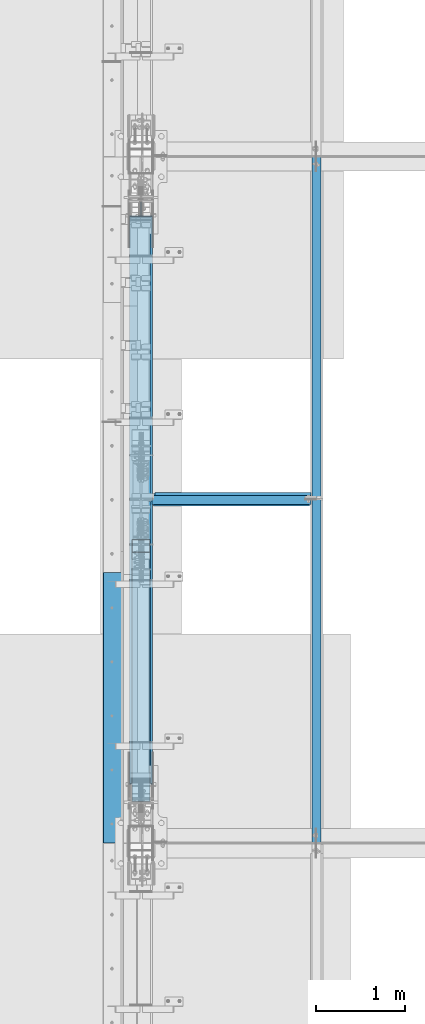
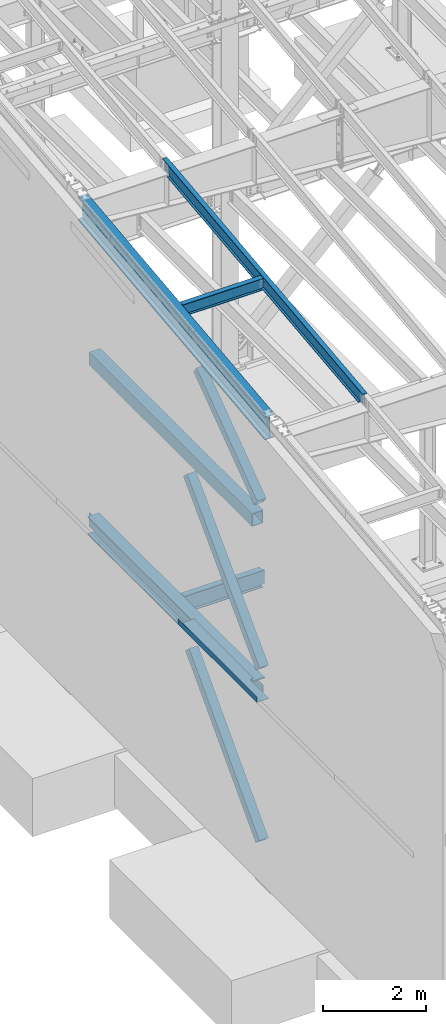
# One storey, part 708 of 1179: 7 beams, 3 members, 9 elements without a shape of their own.
"""IFC2X3 building model written with IfcOpenShell, lengths in millimetres."""

from ifc_helpers import new_model, si_unit, frame, origin_with_axes, place, context, subcontext, project, spatial, faceted_brep, material, type_object, element, aggregate, save


model = new_model("IFC2X3")

# Units and contexts
model_context = context("Model", 3, precision=1e-05, world=origin_with_axes())
body_context = subcontext(model_context, "Body", "Model", "MODEL_VIEW")
ifc_project = project(units=[si_unit("LENGTHUNIT", "METRE", prefix="MILLI"), si_unit("AREAUNIT", "SQUARE_METRE"), si_unit("VOLUMEUNIT", "CUBIC_METRE"), si_unit("MASSUNIT", "GRAM", prefix="KILO"), si_unit("TIMEUNIT", "SECOND"), si_unit("PLANEANGLEUNIT", "RADIAN"), si_unit("SOLIDANGLEUNIT", "STERADIAN"), si_unit("THERMODYNAMICTEMPERATUREUNIT", "DEGREE_CELSIUS"), si_unit("LUMINOUSINTENSITYUNIT", "LUMEN")], contexts=[model_context])

# Site, building, storey
site_placement = place(None, origin_with_axes())
site = spatial("IfcSite", under=ifc_project, at=site_placement, CompositionType="ELEMENT")
building_placement = place(site_placement, origin_with_axes())
building = spatial("IfcBuilding", under=site, at=building_placement, Name="Undefined", CompositionType="ELEMENT")
storey_placement = place(building_placement, origin_with_axes())
storey = spatial("IfcBuildingStorey", under=building, at=storey_placement, Name="Undefined", CompositionType="ELEMENT", Elevation=0.0)

# Assembly, beam
assembly_1_placement = place(storey_placement, origin_with_axes())
assembly_1 = element("IfcElementAssembly", 1, at=assembly_1_placement, inside=storey, Name="BEAM", AssemblyPlace="NOTDEFINED", PredefinedType="RIGID_FRAME")
ifc_material_1 = material(Name="STEEL/A992")
beam_type_1 = type_object("IfcBeamType", Name="W16X31", PredefinedType="NOTDEFINED")
beam_1_placement = place(assembly_1_placement, frame((431.800000000002, 15354.3, 3900.4875), z_axis=(0.0, 0.0, 1.0), x_axis=(1.0, 0.0, 0.0)))
beam_1 = element("IfcBeam", 2, at=beam_1_placement, type_object=beam_type_1, material=ifc_material_1, Name="BEAM", ObjectType="W16X31", context=body_context, shape_type="Brep", body=[
    faceted_brep([(1965.32485351562, -3.17499999999927, 169.862500000001), (1965.32485351562, 3.17499999999927, 169.862500000001), (1911.34985332489, 3.17499999999927, 169.862500000001), (1911.34985332489, -3.17499999999927, 169.862500000001), (1906.48977380684, 3.17499999999927, 170.829229922589), (1906.48977380684, -3.17499999999927, 170.829229922589), (1902.36959733869, 3.17499999999927, 173.582243823067), (1902.36959733869, -3.17499999999927, 173.582243823067), (1901.82485351562, 3.17499999999927, 174.397510567854), (1899.61658343821, 3.17499999999927, 177.70242029122), (1899.61658343821, -3.17499999999927, 177.70242029122), (1898.64985351562, 3.17499999999927, 182.562499809266), (1898.64985351562, -3.17499999999927, 182.562499809266), (142.081250000001, 3.17499999999927, 190.5), (142.081250000001, 69.8499999999985, 190.5), (1898.64985351562, 69.8500000000004, 190.5), (1898.64985351562, 3.17499999999927, 190.5), (142.081250000001, -69.8499999999985, 201.6125), (142.081250000001, -69.8499999999985, 190.5), (1898.64985351562, -69.8500000000004, 190.5), (1898.64985351562, -69.8500000000004, 201.6125), (142.081250000001, 69.8499999999985, 201.6125), (1898.64985351562, 69.8500000000004, 201.6125), (1898.64985351562, -3.17499999999927, 190.5), (142.081250000001, -3.17499999999927, 190.5), (142.08125, 3.17499999999927, 169.862499809265), (142.08125, -3.17499999999927, 169.862499809265), (141.114520077412, 3.17499999999927, 165.00242029122), (141.114520077412, -3.17499999999927, 165.00242029122), (138.361506176934, 3.17499999999927, 160.882243823066), (138.361506176934, -3.17499999999927, 160.882243823066), (134.24132970878, 3.17499999999927, 158.129229922588), (134.24132970878, -3.17499999999927, 158.129229922588), (129.381250190735, 3.17499999999927, 157.1625), (129.381250190735, -3.17499999999927, 157.1625), (18.2562499999996, 3.17499999999927, 157.1625), (18.2562499999996, -3.17499999999927, 157.1625), (18.2562499999996, 3.17499999999927, -157.1625), (18.2562499999996, -3.17499999999927, -157.1625), (129.381250190735, 3.17499999999927, -157.1625), (129.381250190735, -3.17499999999927, -157.1625), (134.24132970878, 3.17499999999927, -158.129229922588), (134.24132970878, -3.17499999999927, -158.129229922588), (138.361506176934, 3.17499999999927, -160.882243823066), (138.361506176934, -3.17499999999927, -160.882243823066), (141.114520077412, 3.17499999999927, -165.00242029122), (141.114520077412, -3.17499999999927, -165.00242029122), (142.08125, 3.17499999999927, -169.862499809266), (142.08125, -3.17499999999927, -169.862499809266), (142.081250000001, 3.17499999999927, -190.5), (142.081250000001, 69.8499999999985, -190.5), (142.081250000001, 69.8499999999985, -201.6125), (142.081250000001, -69.8499999999985, -201.6125), (142.081250000001, -69.8499999999985, -190.5), (142.081250000001, -3.17499999999927, -190.5), (1898.64985351562, 3.17499999999927, -190.5), (1898.64985351562, 69.8500000000004, -190.5), (1898.64985351562, 69.8500000000004, -201.6125), (1898.64985351562, -69.8500000000004, -201.6125), (1898.64985351562, -69.8500000000004, -190.5), (1898.64985351562, -3.17499999999927, -190.5), (1898.64985351562, -3.17499999999927, -182.562499809264), (1899.61658343821, -3.17499999999927, -177.702420291219), (1902.36959733869, -3.17499999999927, -173.582243823065), (1906.48977380684, -3.17499999999927, -170.829229922587), (1911.34985332489, -3.17499999999927, -169.862499999999), (1965.32485351562, -3.17499999999927, -169.862499999999), (1965.32485351562, 3.17499999999927, -169.862499999999), (1906.48977380684, 3.17499999999927, -170.829229922587), (1902.36959733869, 3.17499999999927, -173.582243823065), (1901.82485351562, 3.17499999999927, -174.397510567853), (1899.61658343821, 3.17499999999927, -177.702420291219), (1898.64985351562, 3.17499999999927, -182.562499809264), (1911.34985332489, 3.17499999999927, -169.862499999999)], [[[0, 1, 2, 3]], [[3, 2, 4, 5]], [[5, 4, 6, 7]], [[7, 6, 8, 9, 10]], [[10, 9, 11, 12]], [[13, 14, 15, 16]], [[17, 18, 19, 20]], [[21, 17, 20, 22]], [[14, 21, 22, 15]], [[20, 19, 23, 12, 11, 16, 15, 22]], [[18, 24, 23, 19]], [[17, 21, 14, 13, 25, 26, 24, 18]], [[26, 25, 27, 28]], [[28, 27, 29, 30]], [[30, 29, 31, 32]], [[32, 31, 33, 34]], [[34, 33, 35, 36]], [[36, 35, 37, 38]], [[38, 37, 39, 40]], [[40, 39, 41, 42]], [[42, 41, 43, 44]], [[44, 43, 45, 46]], [[46, 45, 47, 48]], [[48, 47, 49, 50, 51, 52, 53, 54]], [[50, 49, 55, 56]], [[51, 50, 56, 57]], [[52, 51, 57, 58]], [[53, 52, 58, 59]], [[54, 53, 59, 60]], [[0, 3, 5, 7, 10, 12, 23, 24, 26, 28, 30, 32, 34, 36, 38, 40, 42, 44, 46, 48, 54, 60, 61, 62, 63, 64, 65, 66]], [[1, 0, 66, 67]], [[68, 69, 70, 71, 72, 55, 49, 47, 45, 43, 41, 39, 37, 35, 33, 31, 29, 27, 25, 13, 16, 11, 9, 8, 6, 4, 2, 1, 67, 73]], [[66, 65, 73, 67]], [[64, 68, 73, 65]], [[63, 69, 68, 64]], [[62, 71, 70, 69, 63]], [[61, 72, 71, 62]], [[60, 59, 58, 57, 56, 55, 72, 61]]]),
])
aggregate(assembly_1, [beam_1])

# Assembly, member
assembly_2_placement = place(storey_placement, origin_with_axes())
assembly_2 = element("IfcElementAssembly", 3, at=assembly_2_placement, inside=storey, Name="None", AssemblyPlace="NOTDEFINED", PredefinedType="RIGID_FRAME")
member_type = type_object("IfcMemberType", Name="HSS8X8X3/16", PredefinedType="NOTDEFINED")
member_1_placement = place(assembly_2_placement, frame((431.800000000002, 12102.6825319676, 8317.9321736996), z_axis=(1.0, 0.0, 0.0), x_axis=(0.0, 0.806043266248581, 0.591856615182528)))
member_1 = element("IfcMember", 4, at=member_1_placement, type_object=member_type, material=ifc_material_1, Name="None", ObjectType="HSS8X8X3/16", context=body_context, shape_type="Brep", body=[
    faceted_brep([(-3.63797880709171e-12, 96.8374999999978, -96.8375000000015), (-3.63797880709171e-12, -96.8374999999978, -96.8375000000015), (2914.65000001991, -96.8374999971984, -96.8375), (2914.65000001972, 96.8375000027499, -96.8375), (-3.63797880709171e-12, -96.8374999999978, 96.8375000000015), (2914.65000001991, -96.8374999971984, 96.8375), (-3.63797880709171e-12, 96.8374999999978, 96.8375000000015), (2914.65000001972, 96.8375000027499, 96.8375), (-3.63797880709171e-12, 101.599999999999, -101.599999999999), (-3.63797880709171e-12, 101.599999999999, 101.599999999999), (2914.65000001972, 101.600000002747, 101.6), (2914.65000001972, 101.600000002747, -101.6), (0.0, -101.599999999999, 101.599999999999), (2914.65000001991, -101.599999997197, 101.6), (0.0, -101.599999999999, -101.599999999999), (2914.65000001991, -101.599999997197, -101.6)], [[[0, 1, 2, 3]], [[1, 4, 5, 2]], [[4, 6, 7, 5]], [[6, 0, 3, 7]], [[8, 9, 10, 11]], [[9, 12, 13, 10]], [[12, 14, 15, 13]], [[14, 8, 11, 15]], [[13, 15, 11, 10], [5, 7, 3, 2]], [[14, 12, 9, 8], [6, 4, 1, 0]]]),
])
aggregate(assembly_2, [member_1])

assembly_3_placement = place(storey_placement, origin_with_axes())
assembly_3 = element("IfcElementAssembly", 5, at=assembly_3_placement, inside=storey, Name="None", AssemblyPlace="NOTDEFINED", PredefinedType="RIGID_FRAME")
member_2_placement = place(assembly_3_placement, frame((431.799998474123, 12024.6144774088, 4449.73696522314), z_axis=(1.0, 0.0, 0.0), x_axis=(0.0, 0.698466923036852, 0.715642339037758)))
member_2 = element("IfcMember", 6, at=member_2_placement, type_object=member_type, material=ifc_material_1, Name="None", ObjectType="HSS8X8X3/16", context=body_context, shape_type="Brep", body=[
    faceted_brep([(-3.63797880709171e-12, 96.8374999999978, -96.8375000000015), (-3.63797880709171e-12, -96.8374999999978, -96.8375000000015), (4020.12361600279, -96.837499999664, -96.8375), (4020.12361600291, 96.8375000002379, -96.8375), (-3.63797880709171e-12, -96.8374999999978, 96.8375000000015), (4020.12361600279, -96.837499999664, 96.8375), (-3.63797880709171e-12, 96.8374999999978, 96.8375000000015), (4020.12361600291, 96.8375000002379, 96.8375), (-3.63797880709171e-12, 101.599999999999, -101.599999999999), (-3.63797880709171e-12, 101.599999999999, 101.599999999999), (4020.12361600291, 101.600000000234, 101.6), (4020.12361600291, 101.600000000234, -101.6), (0.0, -101.599999999999, 101.599999999999), (4020.12361600278, -101.599999999662, 101.6), (0.0, -101.599999999999, -101.599999999999), (4020.12361600278, -101.599999999662, -101.6)], [[[0, 1, 2, 3]], [[1, 4, 5, 2]], [[4, 6, 7, 5]], [[6, 0, 3, 7]], [[8, 9, 10, 11]], [[9, 12, 13, 10]], [[12, 14, 15, 13]], [[14, 8, 11, 15]], [[13, 15, 11, 10], [5, 7, 3, 2]], [[14, 12, 9, 8], [6, 4, 1, 0]]]),
])
aggregate(assembly_3, [member_2])

assembly_4_placement = place(storey_placement, origin_with_axes())
assembly_4 = element("IfcElementAssembly", 7, at=assembly_4_placement, inside=storey, Name="None", AssemblyPlace="NOTDEFINED", PredefinedType="RIGID_FRAME")
member_3_placement = place(assembly_4_placement, frame((431.800000000002, 12032.5736527125, 369.341890750087), z_axis=(1.0, 0.0, 0.0), x_axis=(0.0, 0.685995858758672, 0.727605443744034)))
member_3 = element("IfcMember", 8, at=member_3_placement, type_object=member_type, material=ifc_material_1, Name="None", ObjectType="HSS8X8X3/16", context=body_context, shape_type="Brep", body=[
    faceted_brep([(-3.63797880709171e-12, 96.8374999999978, -96.8375000000015), (-3.63797880709171e-12, -96.8374999999978, -96.8375000000015), (3968.75000001255, -96.8375000016003, -96.8375), (3968.75000001275, 96.8374999981806, -96.8375), (-3.63797880709171e-12, -96.8374999999978, 96.8375000000015), (3968.75000001255, -96.8375000016003, 96.8375), (-3.63797880709171e-12, 96.8374999999978, 96.8375000000015), (3968.75000001275, 96.8374999981806, 96.8375), (-3.63797880709171e-12, 101.599999999999, -101.599999999999), (-3.63797880709171e-12, 101.599999999999, 101.599999999999), (3968.75000001276, 101.599999998176, 101.6), (3968.75000001276, 101.599999998176, -101.6), (0.0, -101.599999999999, 101.599999999999), (3968.75000001255, -101.600000001596, 101.6), (0.0, -101.599999999999, -101.599999999999), (3968.75000001255, -101.600000001596, -101.6)], [[[0, 1, 2, 3]], [[1, 4, 5, 2]], [[4, 6, 7, 5]], [[6, 0, 3, 7]], [[8, 9, 10, 11]], [[9, 12, 13, 10]], [[12, 14, 15, 13]], [[14, 8, 11, 15]], [[13, 15, 11, 10], [5, 7, 3, 2]], [[14, 12, 9, 8], [6, 4, 1, 0]]]),
])
aggregate(assembly_4, [member_3])

# Assembly, beam
assembly_5_placement = place(storey_placement, origin_with_axes())
assembly_5 = element("IfcElementAssembly", 9, at=assembly_5_placement, inside=storey, Name="BEAM", AssemblyPlace="NOTDEFINED", PredefinedType="RIGID_FRAME")
ifc_material_2 = material(Name="STEEL/A36")
beam_type_2 = type_object("IfcBeamType", PredefinedType="NOTDEFINED")
beam_2_placement = place(assembly_5_placement, frame((352.424987792969, 13007.975, 4105.275), z_axis=(0.0, -1.0, 0.0), x_axis=(-1.0, 0.0, 0.0)))
beam_2 = element("IfcBeam", 10, at=beam_2_placement, type_object=beam_type_2, material=ifc_material_2, Name="BENT_PLATE", context=body_context, shape_type="Brep", body=[
    faceted_brep([(84.1374893188476, -3.17500000000018, 788.651567305722), (84.1374893188476, 3.17500000000018, 788.651567305722), (0.0, 3.17500000000018, 788.651567305722), (0.0, -3.17500000000018, 788.651567305722), (84.1374893188477, -3.17500000000018, 1524.0), (84.1374893188477, 3.17500000000018, 1524.0), (346.074987792969, -3.17500000000109, -1524.0), (0.0, -3.17499999999927, -1524.0), (0.0, 3.17499999999927, -1524.0), (352.424987792969, 3.17499999999927, -1524.0), (352.424987792969, -130.175006103515, -1524.0), (346.074987792969, -130.175006103515, -1524.0), (352.424987792969, 3.17499999999927, 1524.0), (352.424987792969, -130.175006103515, 1524.0), (346.074987792969, -130.175006103515, 1524.0), (346.074987792969, -3.17500000000109, 1524.0)], [[[0, 1, 2, 3]], [[4, 5, 1, 0]], [[6, 7, 8, 9, 10, 11]], [[9, 12, 13, 10]], [[14, 11, 10, 13]], [[15, 6, 11, 14]], [[3, 7, 6, 15, 4, 0]], [[8, 7, 3, 2]], [[12, 9, 8, 2, 1, 5]], [[15, 14, 13, 12, 5, 4]]]),
])

assembly_6_placement = place(storey_placement, origin_with_axes())
assembly_6 = element("IfcElementAssembly", 11, at=assembly_6_placement, inside=storey, Name="BEAM", AssemblyPlace="NOTDEFINED", PredefinedType="RIGID_FRAME")
beam_type_3 = type_object("IfcBeamType", Name="W12X22", PredefinedType="NOTDEFINED")
beam_3_placement = place(assembly_6_placement, frame((431.800000000002, 15371.7779321814, 10827.3055548262), z_axis=(0.0, -0.112284087038017, 0.993676146336441), x_axis=(1.0, 0.0, 0.0)))
beam_3 = element("IfcBeam", 12, at=beam_3_placement, type_object=beam_type_3, material=ifc_material_1, Name="BEAM", ObjectType="W12X22", context=body_context, shape_type="Brep", body=[
    faceted_brep([(1917.7, -3.1750000000502, -144.462499999914), (1917.7, -50.8000000000247, -144.462499999896), (1917.7, -50.8000000000284, -155.574999999892), (1917.7, 50.7999999999156, -155.574999999932), (1917.7, 50.7999999999192, -144.46249999994), (1917.7, 3.17499999869324, -144.462499999918), (1917.7, 3.17499998151106, -142.874999810523), (1917.7, -3.17500000004657, -142.874999810521), (1918.66672992259, 3.17499998191852, -138.014920292486), (1918.66672992259, -3.17500000004657, -138.014920292482), (1921.41974382307, 3.17499998226413, -133.894743824339), (1921.41974382307, -3.17500000004293, -133.894743824334), (1925.53992029122, 3.17499998249332, -131.141729923864), (1925.53992029122, -3.17500000004293, -131.141729923862), (1930.39999980926, 3.17499998257699, -130.175000001278), (1930.39999980926, -3.17500000004293, -130.175000001276), (1965.325, -3.17500000004293, -130.175000001276), (1965.325, 3.17499999995198, -130.175000001278), (121.44375, 3.17500000006476, 144.462499999918), (121.44375, 50.8000000000357, 144.4624999999), (1917.7, 50.8000000000357, 144.4624999999), (1917.7, 3.17500000006476, 144.462499999918), (159.54375, 50.7999999999192, -144.46249999994), (159.54375, 50.7999999999156, -155.574999999932), (159.54375, 3.17499995235266, -155.574999999913), (159.54375, 3.17499995235994, -144.462499999918), (19.8437500000002, 3.17499995235266, -155.574999999913), (19.8437500000002, 3.17499999994834, -144.46249999992), (19.8437500000002, -50.8000000000284, -155.574999999892), (19.8437500000002, -50.8000000000247, -144.462499999896), (19.8437500000002, -3.1750000000502, -144.462499999914), (19.8437500000002, -3.1749999999447, 117.474999998307), (19.8437500000002, 3.17500000005384, 117.474999998303), (108.743750190735, -3.1749999999447, 117.474999998307), (108.743750190735, 3.17500000199652, 117.474999998303), (113.603829708781, -3.1749999999447, 118.441729920891), (113.603829708781, 3.17500000207292, 118.441729920887), (117.724006176934, -3.1749999999447, 121.194743821365), (117.724006176934, 3.17500000229848, 121.194743821363), (120.477020077412, -3.17499999993743, 125.314920289511), (120.477020077412, 3.17500000264045, 125.314920289509), (121.44375, -3.17499999993743, 130.174999807548), (121.44375, 3.17500000304426, 130.174999807547), (121.44375, -50.799999999901, 155.574999999935), (121.44375, 50.8000000000429, 155.574999999893), (121.44375, -3.17499999993379, 144.462499999923), (121.44375, -50.7999999999047, 144.462499999941), (1917.7, -3.17499999993379, 144.462499999923), (1917.7, -50.7999999999047, 144.462499999941), (1917.7, -50.799999999901, 155.574999999935), (1917.7, 50.8000000000429, 155.574999999893), (1917.7, -3.17499999993015, 142.874999807531), (1917.7, 3.17500000523796, 142.874999807529), (1918.66672992259, -3.17499999993379, 138.014920289494), (1918.66672992259, 3.17500000483415, 138.01492028949), (1921.41974382307, -3.17499999993743, 133.894743821347), (1921.41974382307, 3.17500000449218, 133.894743821345), (1925.53992029122, -3.17499999993379, 131.141729920873), (1925.53992029122, 3.17500000425935, 131.141729920872), (1930.39999980926, -3.17499999994106, 130.174999998288), (1930.39999980926, 3.17500000417931, 130.174999998286), (1965.325, -3.17499999994106, 130.174999998288), (1965.325, 3.17500000005748, 130.174999998284)], [[[0, 1, 2, 3, 4, 5, 6, 7]], [[7, 6, 8, 9]], [[9, 8, 10, 11]], [[11, 10, 12, 13]], [[13, 12, 14, 15]], [[16, 15, 14, 17]], [[18, 19, 20, 21]], [[22, 23, 24, 25]], [[25, 24, 26, 27]], [[27, 26, 28, 29, 30, 31, 32]], [[33, 34, 32, 31]], [[35, 36, 34, 33]], [[37, 38, 36, 35]], [[39, 40, 38, 37]], [[41, 42, 40, 39]], [[43, 44, 19, 18, 42, 41, 45, 46]], [[46, 45, 47, 48]], [[43, 46, 48, 49]], [[44, 43, 49, 50]], [[19, 44, 50, 20]], [[49, 48, 47, 51, 52, 21, 20, 50]], [[53, 54, 52, 51]], [[55, 56, 54, 53]], [[57, 58, 56, 55]], [[59, 60, 58, 57]], [[61, 62, 60, 59]], [[62, 61, 16, 17]], [[12, 10, 8, 6, 5, 25, 27, 32, 34, 36, 38, 40, 42, 18, 21, 52, 54, 56, 58, 60, 62, 17, 14]], [[22, 25, 5, 4]], [[23, 22, 4, 3]], [[28, 26, 24, 23, 3, 2]], [[29, 28, 2, 1]], [[30, 29, 1, 0]], [[61, 59, 57, 55, 53, 51, 47, 45, 41, 39, 37, 35, 33, 31, 30, 0, 7, 9, 11, 13, 15, 16]]]),
])
aggregate(assembly_6, [beam_3])

assembly_7_placement = place(storey_placement, origin_with_axes())
assembly_7 = element("IfcElementAssembly", 13, at=assembly_7_placement, inside=storey, Name="BEAM", AssemblyPlace="NOTDEFINED", PredefinedType="RIGID_FRAME")
beam_4_placement = place(assembly_7_placement, frame((2413.0, 11498.2779321842, 10389.6051906331), z_axis=(0.0, -0.112284087038017, 0.993676146336441), x_axis=(0.0, 0.993676146336441, 0.112284087038017)))
beam_4 = element("IfcBeam", 14, at=beam_4_placement, type_object=beam_type_3, material=ifc_material_1, Name="BEAM", ObjectType="W12X22", context=body_context, shape_type="Brep", body=[
    faceted_brep([(7583.46730043383, -3.17499999999927, -144.462500002994), (7583.46730043383, -50.7999999999993, -144.462500002994), (7582.21160266769, -50.7999999999993, -155.575000002988), (7582.21160266769, 50.7999999999993, -155.575000002988), (7583.46730043383, 50.7999999999993, -144.462500002994), (7583.46730043383, 3.17499999999927, -144.462500002994), (7586.83832669432, 3.17499999999927, -114.630059163946), (7586.83832669432, -3.17499999999927, -114.630059163946), (7588.34465274973, 3.17499999999927, -109.909262464753), (7588.34465274973, -3.17499999999927, -109.909262464753), (7591.54288724583, 3.17499999999927, -106.124261042249), (7591.54288724583, -3.17499999999927, -106.124261042249), (7595.94612797272, 3.17499999999927, -103.851287051781), (7595.94612797272, -3.17499999999927, -103.851287051781), (7600.88402144536, 3.17499999999927, -103.436380178771), (7600.88402144536, -3.17499999999927, -103.436380178771), (7758.6208335002, -3.17499999999927, -121.260430776909), (7758.62083354224, 3.17499999999927, -121.26043078166), (6.38101702707718, -50.7999999999993, 155.574999999912), (5.12531926095107, -50.7999999999993, 144.46249999992), (7788.64717240277, -50.7999999999993, 144.462499996762), (7789.9028701689, -50.7999999999993, 155.574999996754), (6.38101702707718, 50.7999999999993, 155.574999999912), (7789.9028701689, 50.7999999999993, 155.574999996754), (5.12531926095107, 50.7999999999993, 144.46249999992), (7788.64717240277, 50.7999999999993, 144.462499996762), (5.12531926095107, 3.17499999999927, 144.46249999992), (7788.64717240277, 3.17499999999927, 144.462499996762), (145.30344487597, -3.17499999999927, -142.022226300664), (145.30344487597, 3.17499999999927, -142.022226300664), (145.027696926005, 3.17499999999927, -144.462499999976), (145.027696926005, 50.7999999999993, -144.462499999976), (143.771999161854, 50.7999999999993, -155.574999999972), (143.771999161854, -50.7999999999993, -155.574999999972), (145.027696926005, -50.7999999999993, -144.462499999976), (145.027696926005, -3.17499999999927, -144.462499999976), (-25.0716067072917, -3.17499999999927, -122.770071196437), (-25.0716067072917, 3.17499999999927, -122.770071196437), (5.12531926095107, -3.17499999999927, 144.46249999992), (7788.64717240277, -3.17499999999927, 144.462499996762)], [[[0, 1, 2, 3, 4, 5, 6, 7]], [[7, 6, 8, 9]], [[9, 8, 10, 11]], [[11, 10, 12, 13]], [[13, 12, 14, 15]], [[16, 15, 14, 17]], [[18, 19, 20, 21]], [[22, 18, 21, 23]], [[24, 22, 23, 25]], [[26, 24, 25, 27]], [[28, 29, 30, 31, 32, 33, 34, 35]], [[36, 37, 29, 28]], [[38, 19, 18, 22, 24, 26, 37, 36]], [[19, 38, 39, 20]], [[27, 25, 23, 21, 20, 39, 16, 17]], [[12, 10, 8, 6, 5, 30, 29, 37, 26, 27, 17, 14]], [[31, 30, 5, 4]], [[32, 31, 4, 3]], [[33, 32, 3, 2]], [[34, 33, 2, 1]], [[35, 34, 1, 0]], [[39, 38, 36, 28, 35, 0, 7, 9, 11, 13, 15, 16]]]),
])
aggregate(assembly_7, [beam_4])

assembly_8_placement = place(storey_placement, origin_with_axes())
assembly_8 = element("IfcElementAssembly", 15, at=assembly_8_placement, inside=storey, Name="BEAM", AssemblyPlace="NOTDEFINED", PredefinedType="RIGID_FRAME")
beam_type_4 = type_object("IfcBeamType", Name="W21X93", PredefinedType="NOTDEFINED")
beam_5_placement = place(assembly_8_placement, frame((431.800000000002, 11511.6467563166, 10271.2956244622), z_axis=(0.0, -0.112284087038017, 0.993676146336441), x_axis=(0.0, 0.993676146336441, 0.112284087038017)))
beam_5 = element("IfcBeam", 16, at=beam_5_placement, type_object=beam_type_4, material=ifc_material_1, Name="BEAM", ObjectType="W21X93", context=body_context, shape_type="Brep", body=[
    faceted_brep([(199.930151815766, -106.362499999999, -274.637499999924), (199.930151815766, 106.362499999999, -274.637499999924), (7473.81664542463, 106.362499999999, -274.637500002875), (7473.81664542463, -106.362499999999, -274.637500002875), (202.620932743182, -106.362499999999, -250.824999999939), (202.620932743182, -7.14374999999927, -250.824999999939), (214.511782852391, -7.14375000000001, -145.595003258248), (259.165541301194, -7.14375000000001, 249.575637438327), (259.306717614098, -7.14374999999927, 250.824999999757), (259.306717614098, -106.362499999999, 250.824999999757), (261.997498541514, -106.362499999999, 274.637499999742), (261.997498541514, 106.362499999999, 274.637499999742), (259.306717614098, 106.362499999999, 250.824999999757), (259.306717614098, 7.14374999999927, 250.824999999757), (202.620932743182, 7.14374999999927, -250.824999999939), (202.620932743182, 106.362499999999, -250.824999999939), (7476.50742635205, -106.362499999999, -250.825000002889), (7476.50742635205, -7.14374999999927, -250.825000002889), (7482.50838470353, -7.14375000000001, -197.718550760641), (7527.16214315228, -7.14375000000001, 197.452089935483), (7533.19321122296, -7.14374999999927, 250.824999996807), (7533.19321122296, -106.362499999999, 250.824999996807), (7535.88399215038, -106.362499999999, 274.637499996792), (7535.88399215038, 106.362499999999, 274.637499996792), (7533.19321122296, 106.362499999999, 250.824999996807), (7533.19321122296, 7.14374999999927, 250.824999996807), (7476.50742635205, 7.14374999999927, -250.825000002889), (7476.50742635205, 106.362499999999, -250.825000002889)], [[[0, 1, 2, 3]], [[0, 4, 5, 6, 7, 8, 9, 10, 11, 12, 13, 14, 15, 1]], [[5, 4, 16, 17]], [[8, 7, 6, 5, 17, 18, 19, 20]], [[9, 8, 20, 21]], [[10, 9, 21, 22]], [[11, 10, 22, 23]], [[12, 11, 23, 24]], [[13, 12, 24, 25]], [[14, 13, 25, 26]], [[15, 14, 26, 27]], [[1, 15, 27, 2]], [[26, 25, 24, 23, 22, 21, 20, 19, 18, 17, 16, 3, 2, 27]], [[4, 0, 3, 16]]]),
])
aggregate(assembly_8, [beam_5])

# Beam
beam_type_5 = type_object("IfcBeamType", Name="W16X77", PredefinedType="NOTDEFINED")
beam_6_placement = place(assembly_5_placement, frame((431.800000000002, 11981.1984303375, 3892.55), z_axis=(0.0, 0.0, 1.0), x_axis=(0.0, 1.0, 0.0)))
beam_6 = element("IfcBeam", 17, at=beam_6_placement, type_object=beam_type_5, material=ifc_material_1, Name="BEAM", ObjectType="W16X77", context=body_context, shape_type="Brep", body=[
    faceted_brep([(6584.27739073618, -130.175, 190.5), (6584.27739073618, -5.55624999999998, 190.5), (6584.50659997144, -5.55624999999998, 190.103), (6584.50659997144, 5.55625000000003, 190.103), (6584.27739073618, 5.55624999999998, 190.5), (6584.27739073618, 130.175, 190.5), (6573.27881156346, 130.175, 209.55), (6573.27881156346, -130.175, 209.55), (172.923597538524, -130.174999999999, -190.5), (161.925402461478, -130.174999999999, -209.55), (6584.27699063147, -130.175, -209.55), (6573.27879555443, -130.175, -190.5), (161.925402461478, 130.174999999999, -209.55), (6584.27699063147, 130.175, -209.55), (172.923597538524, 130.174999999999, -190.5), (6573.27879555443, 130.175, -190.5), (172.923597538524, 5.55625000000146, -190.5), (6573.27879555443, 5.55624999999998, -190.5), (6526.83802889595, -5.55624999999998, 183.243356973128), (6526.83802889595, 5.55625000000003, 183.243356973128), (6541.41439309295, 5.55625000000003, 190.103), (6541.41439309295, -5.55624999999998, 190.103), (6522.9822802869, -5.55624999999998, 179.929052423033), (6522.9822802869, 5.55625000000003, 179.929052423033), (6521.38085381215, -5.55624999999998, 175.103407882361), (6521.38085381215, 5.55625000000003, 175.103407882361), (6522.49006089289, -5.55624999999998, 170.141445403766), (6522.49006089289, 5.55625000000003, 170.141445403766), (6525.99384339757, -5.55624999999998, 166.457029554973), (6525.99384339757, 5.55625000000003, 166.457029554973), (6530.8938314357, -5.55624999999998, 165.1), (6530.8938314357, 5.55625000000003, 165.1), (6733.50239309295, -5.55624999999998, 165.1), (6733.50239309295, 5.55624999999998, 165.1), (6733.50239309295, -5.55624999999998, -165.1), (6733.50239309295, 5.55624999999998, -165.1), (6530.5498314357, -5.55624999999998, -165.1), (6530.5498314357, 5.55624999999998, -165.1), (6525.64984339756, -5.55624999999998, -166.457029554975), (6525.64984339756, 5.55624999999998, -166.457029554975), (6522.14606089288, -5.55624999999998, -170.141445403767), (6522.14606089288, 5.55624999999998, -170.141445403767), (6521.03685381215, -5.55624999999998, -175.103407882362), (6521.03685381215, 5.55624999999998, -175.103407882362), (6522.6382802869, -5.55624999999998, -179.929052423033), (6522.6382802869, 5.55624999999998, -179.929052423033), (6526.49402889595, -5.55624999999998, -183.243356973127), (6526.49402889595, 5.55624999999998, -183.243356973127), (6541.07039309295, -5.55624999999998, -190.103), (6541.07039309295, 5.55624999999998, -190.103), (6573.04959432369, -5.55624999999998, -190.103), (6573.04959432369, 5.55624999999998, -190.103), (6573.27879555443, -5.55624999999998, -190.5), (172.923597538524, -5.55625000000146, -190.5), (173.152798769261, -5.55625000000146, -190.103), (173.152798769261, 5.55625000000146, -190.103), (205.132000000001, -5.55625000000146, -190.103), (205.132000000001, 5.55625000000146, -190.103), (219.708364197006, -5.55625000000146, -183.243356973128), (219.708364197006, 5.55625000000146, -183.243356973128), (223.564112806052, -5.55625000000146, -179.929052423034), (223.564112806052, 5.55625000000146, -179.929052423034), (225.165539280799, -5.55625000000146, -175.103407882363), (225.165539280799, 5.55625000000146, -175.103407882363), (224.056332200067, -5.55625000000146, -170.141445403768), (224.056332200067, 5.55625000000146, -170.141445403768), (220.552549695389, -5.55625000000146, -166.457029554975), (220.552549695389, 5.55625000000146, -166.457029554975), (215.652561657254, -5.55625000000146, -165.1), (215.652561657254, 5.55625000000146, -165.1), (12.7000000000007, -5.55625000000146, -165.1), (12.7000000000007, 5.55625000000146, -165.1), (12.7000000000007, -5.55625000000146, 165.1), (12.7000000000007, 5.55625000000146, 165.1), (215.308561657253, -5.55625000000146, 165.1), (215.308561657253, 5.55625000000146, 165.1), (220.208549695388, -5.55625000000146, 166.457029554976), (220.208549695388, 5.55625000000146, 166.457029554976), (223.71233220007, -5.55625000000146, 170.141445403769), (223.71233220007, 5.55625000000146, 170.141445403769), (224.821539280802, -5.55625000000146, 175.103407882364), (224.821539280802, 5.55625000000146, 175.103407882364), (223.220112806051, -5.55625000000146, 179.929052423035), (223.220112806051, 5.55625000000146, 179.929052423035), (219.364364197005, -5.55625000000146, 183.243356973128), (219.364364197005, 5.55625000000146, 183.243356973128), (204.788, -5.55625000000146, 190.103), (204.788, 5.55625000000146, 190.103), (161.695793121518, -5.55625000000146, 190.103), (161.695793121518, 5.55625000000146, 190.103), (172.923581529496, -130.174999999999, 209.55), (172.923581529496, 130.174999999999, 209.55), (161.925002356769, 130.174999999999, 190.5), (161.925002356769, 5.55625000000146, 190.5), (161.925002356769, -5.55625000000146, 190.5), (161.925002356769, -130.174999999999, 190.5)], [[[0, 1, 2, 3, 4, 5, 6, 7]], [[8, 9, 10, 11]], [[9, 12, 13, 10]], [[12, 14, 15, 13]], [[14, 16, 17, 15]], [[18, 19, 20, 21]], [[22, 23, 19, 18]], [[24, 25, 23, 22]], [[26, 27, 25, 24]], [[28, 29, 27, 26]], [[30, 31, 29, 28]], [[31, 30, 32, 33]], [[32, 34, 35, 33]], [[36, 37, 35, 34]], [[38, 39, 37, 36]], [[40, 41, 39, 38]], [[42, 43, 41, 40]], [[44, 45, 43, 42]], [[46, 47, 45, 44]], [[48, 49, 47, 46]], [[49, 48, 50, 51]], [[10, 13, 15, 17, 51, 50, 52, 11]], [[53, 8, 11, 52]], [[54, 55, 16, 14, 12, 9, 8, 53]], [[56, 57, 55, 54]], [[58, 59, 57, 56]], [[60, 61, 59, 58]], [[62, 63, 61, 60]], [[64, 65, 63, 62]], [[66, 67, 65, 64]], [[68, 69, 67, 66]], [[69, 68, 70, 71]], [[72, 73, 71, 70]], [[74, 75, 73, 72]], [[76, 77, 75, 74]], [[78, 79, 77, 76]], [[80, 81, 79, 78]], [[82, 83, 81, 80]], [[84, 85, 83, 82]], [[86, 87, 85, 84]], [[87, 86, 88, 89]], [[90, 91, 92, 93, 89, 88, 94, 95]], [[90, 95, 0, 7]], [[91, 90, 7, 6]], [[92, 91, 6, 5]], [[93, 92, 5, 4]], [[20, 19, 23, 25, 27, 29, 31, 33, 35, 37, 39, 41, 43, 45, 47, 49, 51, 17, 16, 55, 57, 59, 61, 63, 65, 67, 69, 71, 73, 75, 77, 79, 81, 83, 85, 87, 89, 93, 4, 3]], [[21, 20, 3, 2]], [[94, 88, 86, 84, 82, 80, 78, 76, 74, 72, 70, 68, 66, 64, 62, 60, 58, 56, 54, 53, 52, 50, 48, 46, 44, 42, 40, 38, 36, 34, 32, 30, 28, 26, 24, 22, 18, 21, 2, 1]], [[95, 94, 1, 0]]]),
])

aggregate(assembly_5, [beam_2, beam_6])

# Assembly, beam
assembly_9_placement = place(storey_placement, origin_with_axes())
assembly_9 = element("IfcElementAssembly", 18, at=assembly_9_placement, inside=storey, Name="BEAM", AssemblyPlace="NOTDEFINED", PredefinedType="RIGID_FRAME")
ifc_material_3 = material()
beam_type_6 = type_object("IfcBeamType", Name="HSS12X10X1/2", PredefinedType="NOTDEFINED")
beam_7_placement = place(assembly_9_placement, frame((431.800000000005, 11558.5875, 7861.3), z_axis=(0.0, 0.0, 1.0), x_axis=(0.0, 1.0, 0.0)))
beam_7 = element("IfcBeam", 19, at=beam_7_placement, type_object=beam_type_6, material=ifc_material_3, Name="BEAM", ObjectType="HSS12X10X1/2", context=body_context, shape_type="Brep", body=[
    faceted_brep([(649.112697461464, 114.3, -139.7), (649.112697461464, -114.3, -139.7), (6942.31230351391, -114.3, -139.7), (6942.31230351391, 114.3, -139.7), (649.112697461464, -114.3, 139.7), (6942.31230351391, -114.3, 139.7), (649.112697461464, 114.3, 139.7), (6942.31230351391, 114.3, 139.7), (649.112697461464, 127.0, -152.4), (649.112697461464, 127.0, 152.4), (6942.31230351391, 127.0, 152.4), (6942.31230351391, 127.0, -152.4), (649.112697461464, -127.0, 152.4), (6942.31230351391, -127.0, 152.4), (649.112697461464, -127.0, -152.4), (6942.31230351391, -127.0, -152.4)], [[[0, 1, 2, 3]], [[1, 4, 5, 2]], [[4, 6, 7, 5]], [[6, 0, 3, 7]], [[8, 9, 10, 11]], [[9, 12, 13, 10]], [[12, 14, 15, 13]], [[14, 8, 11, 15]], [[13, 15, 11, 10], [5, 7, 3, 2]], [[14, 12, 9, 8], [6, 4, 1, 0]]]),
])
aggregate(assembly_9, [beam_7])

save(model, "model.ifc")
